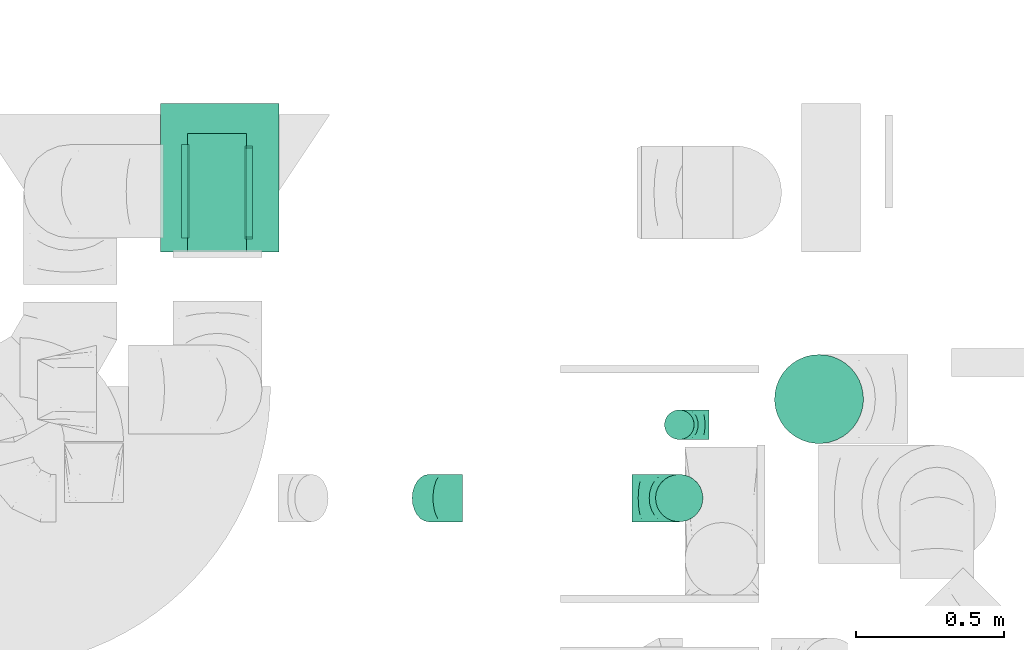
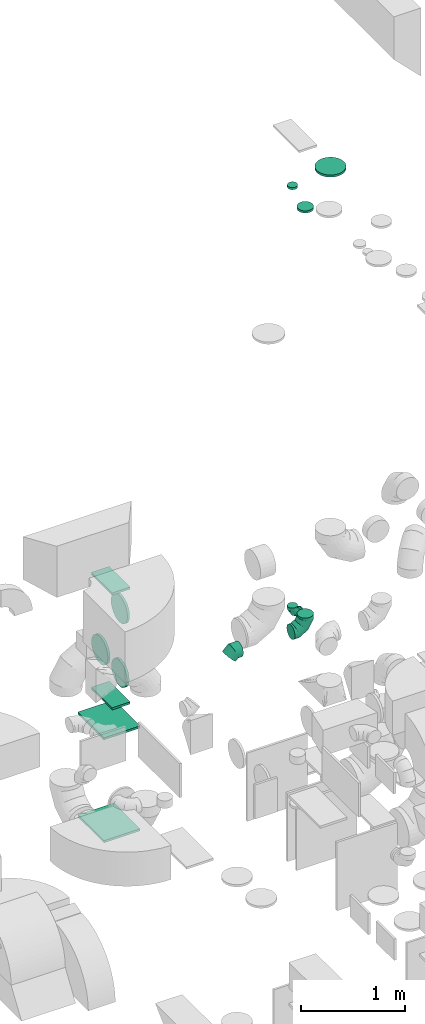
# One storey, part 33 of 59: 13 flow fittings.
"""IFC2X3 building model written with IfcOpenShell, lengths in millimetres."""

from ifc_helpers import new_model, entity, si_unit, converted_unit, derived_unit, direction, frame, origin, origin_2d_with_axis, place, context, subcontext, project, spatial, rectangle, circle, extrude, faceted_brep, source, transform, mapped, material, type_object, type_shapes, element, save


model = new_model("IFC2X3")

# Units and contexts
model_context = context("Model", 3, precision=0.01, world=origin(), true_north=direction((6.12303176911189e-17, 1.0)))
body_context = subcontext(model_context, "Body", "Model", "MODEL_VIEW")
ifc_project = project(units=[si_unit("LENGTHUNIT", "METRE", prefix="MILLI"), si_unit("AREAUNIT", "SQUARE_METRE"), si_unit("VOLUMEUNIT", "CUBIC_METRE"), converted_unit("PLANEANGLEUNIT", "DEGREE", entity("IfcRatioMeasure", 0.0174532925199433), si_unit("PLANEANGLEUNIT", "RADIAN"), dimensions=[0, 0, 0, 0, 0, 0, 0]), si_unit("MASSUNIT", "GRAM", prefix="KILO"), derived_unit("MASSDENSITYUNIT", [(si_unit("MASSUNIT", "GRAM", prefix="KILO"), 1), (si_unit("LENGTHUNIT", "METRE"), -3)]), derived_unit("MOMENTOFINERTIAUNIT", [(si_unit("LENGTHUNIT", "METRE"), 4)]), si_unit("TIMEUNIT", "SECOND"), si_unit("FREQUENCYUNIT", "HERTZ"), si_unit("THERMODYNAMICTEMPERATUREUNIT", "DEGREE_CELSIUS"), derived_unit("THERMALTRANSMITTANCEUNIT", [(si_unit("MASSUNIT", "GRAM", prefix="KILO"), 1), (si_unit("THERMODYNAMICTEMPERATUREUNIT", "KELVIN"), -1), (si_unit("TIMEUNIT", "SECOND"), -3)]), derived_unit("VOLUMETRICFLOWRATEUNIT", [(si_unit("LENGTHUNIT", "METRE"), 3), (si_unit("TIMEUNIT", "SECOND"), -1)]), derived_unit("MASSFLOWRATEUNIT", [(si_unit("MASSUNIT", "GRAM", prefix="KILO"), 1), (si_unit("TIMEUNIT", "SECOND"), -1)]), derived_unit("ROTATIONALFREQUENCYUNIT", [(si_unit("TIMEUNIT", "SECOND"), -1)]), si_unit("ELECTRICCURRENTUNIT", "AMPERE"), si_unit("ELECTRICVOLTAGEUNIT", "VOLT"), si_unit("POWERUNIT", "WATT"), si_unit("FORCEUNIT", "NEWTON", prefix="KILO"), si_unit("ILLUMINANCEUNIT", "LUX"), si_unit("LUMINOUSFLUXUNIT", "LUMEN"), si_unit("LUMINOUSINTENSITYUNIT", "CANDELA"), derived_unit("USERDEFINED", [(si_unit("MASSUNIT", "GRAM", prefix="KILO"), -1), (si_unit("LENGTHUNIT", "METRE"), -2), (si_unit("TIMEUNIT", "SECOND"), 3), (si_unit("LUMINOUSFLUXUNIT", "LUMEN"), 1)]), derived_unit("LINEARVELOCITYUNIT", [(si_unit("LENGTHUNIT", "METRE"), 1), (si_unit("TIMEUNIT", "SECOND"), -1)]), si_unit("PRESSUREUNIT", "PASCAL"), derived_unit("USERDEFINED", [(si_unit("LENGTHUNIT", "METRE"), -2), (si_unit("MASSUNIT", "GRAM", prefix="KILO"), 1), (si_unit("TIMEUNIT", "SECOND"), -2)]), derived_unit("LINEARFORCEUNIT", [(si_unit("MASSUNIT", "GRAM", prefix="KILO"), 1), (si_unit("LENGTHUNIT", "METRE"), 1), (si_unit("TIMEUNIT", "SECOND"), -2), (si_unit("LENGTHUNIT", "METRE"), -1)]), derived_unit("PLANARFORCEUNIT", [(si_unit("MASSUNIT", "GRAM", prefix="KILO"), 1), (si_unit("LENGTHUNIT", "METRE"), 1), (si_unit("TIMEUNIT", "SECOND"), -2), (si_unit("LENGTHUNIT", "METRE"), -2)])], contexts=[model_context])

# Site, building, storey
site_placement = place(None, origin())
site = spatial("IfcSite", under=ifc_project, at=site_placement, CompositionType="ELEMENT")
building_placement = place(site_placement, origin())
building = spatial("IfcBuilding", under=site, at=building_placement, CompositionType="ELEMENT")
storey_placement = place(building_placement, frame((0.0, 0.0, 28200.0)))
storey = spatial("IfcBuildingStorey", under=building, at=storey_placement, CompositionType="ELEMENT", Elevation=28200.0)

# Flow fittings
ifc_material = material()
duct_fitting_type_1 = type_object("IfcDuctFittingType", PredefinedType="NOTDEFINED", material=ifc_material)
shared_shape_1 = source(origin(), body_context, "Body", "SweptSolid", [
    extrude(circle(Radius=79.9999999999994, at=origin_2d_with_axis()), frame((0.0, 0.0, 0.0), z_axis=(1.0, 0.0, 0.0), x_axis=(0.0, 1.0, 0.0)), (0.0, 0.0, 1.0), 25.0000000000018),
])
type_shapes(duct_fitting_type_1, [shared_shape_1])
flow_fitting_1_placement = place(storey_placement, frame((55450.71, 11858.0, 7500.0), z_axis=(-1.0, 0.0, 0.0), x_axis=(0.0, 0.0, 1.0)))
element("IfcFlowFitting", 1, at=flow_fitting_1_placement, inside=storey, type_object=duct_fitting_type_1, material=ifc_material, context=body_context, shape_type="MappedRepresentation", body=[
    mapped(shared_shape_1, transform((0.0, 0.0, 0.0), scale=1.0)),
])
duct_fitting_type_2 = type_object("IfcDuctFittingType", PredefinedType="NOTDEFINED", material=ifc_material)
shared_shape_2 = source(origin(), body_context, "Body", "SweptSolid", [
    extrude(circle(Radius=49.9999999999997, at=origin_2d_with_axis()), frame((0.0, 0.0, 0.0), z_axis=(1.0, 0.0, 0.0), x_axis=(0.0, 1.0, 0.0)), (0.0, 0.0, 1.0), 25.0000000000018),
])
type_shapes(duct_fitting_type_2, [shared_shape_2])
flow_fitting_2_placement = place(storey_placement, frame((55451.0, 12105.64, 7601.3), z_axis=(-1.0, 0.0, 0.0), x_axis=(0.0, 0.0, 1.0)))
element("IfcFlowFitting", 2, at=flow_fitting_2_placement, inside=storey, type_object=duct_fitting_type_2, material=ifc_material, context=body_context, shape_type="MappedRepresentation", body=[
    mapped(shared_shape_2, transform((0.0, 0.0, 0.0), scale=1.0)),
])
duct_fitting_type_3 = type_object("IfcDuctFittingType", PredefinedType="NOTDEFINED", material=ifc_material)
shared_shape_3 = source(origin(), body_context, "Body", "SweptSolid", [
    extrude(rectangle(XDim=24.9999999999999, YDim=500.0, at=origin_2d_with_axis()), frame((12.5, 0.0, -200.0)), (0.0, 0.0, 1.0), 400.0),
])
type_shapes(duct_fitting_type_3, [shared_shape_3])
for number, where, z_axis, x_axis in (
    (3, (53900.03, 12939.46, 200.23), (-1.0, 0.0, 0.0), (0.0, 0.0, -1.0)),
    (4, (53900.03, 12939.46, 1380.23), (-1.0, 0.0, 0.0), (0.0, 0.0, 1.0)),
):
    element("IfcFlowFitting", number, at=place(storey_placement, frame(where, z_axis=z_axis, x_axis=x_axis)), inside=storey, type_object=duct_fitting_type_3, material=ifc_material, context=body_context, shape_type="MappedRepresentation", body=[
        mapped(shared_shape_3, transform((0.0, 0.0, 0.0), scale=1.0)),
    ])
duct_fitting_type_4 = type_object("IfcDuctFittingType", PredefinedType="NOTDEFINED", material=ifc_material)
shared_shape_4 = source(origin(), body_context, "Body", "SweptSolid", [
    extrude(rectangle(XDim=24.9999999999999, YDim=400.0, at=origin_2d_with_axis()), frame((12.5, 0.0, -100.0)), (0.0, 0.0, 1.0), 200.0),
])
type_shapes(duct_fitting_type_4, [shared_shape_4])
for number, where, z_axis, x_axis in (
    (5, (53890.28, 12889.46, 1725.0), (-1.0, 0.0, 0.0), (0.0, 0.0, -1.0)),
    (6, (53890.28, 12889.46, 3045.0), (-1.0, 0.0, 0.0), (0.0, 0.0, 1.0)),
):
    element("IfcFlowFitting", number, at=place(storey_placement, frame(where, z_axis=z_axis, x_axis=x_axis)), inside=storey, type_object=duct_fitting_type_4, material=ifc_material, context=body_context, shape_type="MappedRepresentation", body=[
        mapped(shared_shape_4, transform((0.0, 0.0, 0.0), scale=1.0)),
    ])
duct_fitting_type_5 = type_object("IfcDuctFittingType", PredefinedType="NOTDEFINED", material=ifc_material)
shared_shape_5 = source(origin(), body_context, "Body", "SweptSolid", [
    extrude(circle(Radius=149.999999999999, at=origin_2d_with_axis()), frame((0.0, 0.0, 0.0), z_axis=(1.0, 0.0, 0.0), x_axis=(0.0, 1.0, 0.0)), (0.0, 0.0, 1.0), 25.0000000000018),
])
type_shapes(duct_fitting_type_5, [shared_shape_5])
flow_fitting_3_placement = place(storey_placement, frame((55922.5, 12192.32, 7601.3), z_axis=(-1.0, 0.0, 0.0), x_axis=(0.0, 0.0, 1.0)))
element("IfcFlowFitting", 7, at=flow_fitting_3_placement, inside=storey, type_object=duct_fitting_type_5, material=ifc_material, context=body_context, shape_type="MappedRepresentation", body=[
    mapped(shared_shape_5, transform((0.0, 0.0, 0.0), scale=1.0)),
])
duct_fitting_type_6 = type_object("IfcDuctFittingType", PredefinedType="NOTDEFINED", material=ifc_material)
shared_shape_6 = source(origin(), body_context, "Body", "Brep", [
    faceted_brep([(-160.0, 0.0, -80.0), (-160.0, -20.71, -77.27), (-160.0, -40.0, -69.28), (-160.0, -56.57, -56.57), (-160.0, -69.28, -40.0), (-160.0, -77.27, -20.71), (-160.0, -80.0, 0.0), (-160.0, -77.27, 20.71), (-160.0, -69.28, 40.0), (-160.0, -56.57, 56.57), (-160.0, -40.0, 69.28), (-160.0, -20.71, 77.27), (-160.0, 0.0, 80.0), (-160.0, 20.71, 77.27), (-160.0, 40.0, 69.28), (-160.0, 56.57, 56.57), (-160.0, 69.28, 40.0), (-160.0, 77.27, 20.71), (-160.0, 80.0, 0.0), (-160.0, 77.27, -20.71), (-160.0, 69.28, -40.0), (-160.0, 56.57, -56.57), (-160.0, 40.0, -69.28), (-160.0, 20.71, -77.27), (-122.68, 20.71, 77.27), (-127.85, 40.0, 69.28), (-117.13, 0.0, 80.0), (-132.29, 56.57, 56.57), (-137.83, 77.27, 20.71), (-138.56, 80.0, 0.0), (-135.69, 69.28, 40.0), (-135.69, 69.28, -40.0), (-132.29, 56.57, -56.57), (-137.83, 77.27, -20.71), (-122.68, 20.71, -77.27), (-117.13, 0.0, -80.0), (-127.85, 40.0, -69.28), (-111.58, -20.71, -77.27), (-106.41, -40.0, -69.28), (-101.97, -56.57, -56.57), (-98.56, -69.28, -40.0), (-96.42, -77.27, -20.71), (-95.69, -80.0, 0.0), (-96.42, -77.27, 20.71), (-98.56, -69.28, 40.0), (-101.97, -56.57, 56.57), (-106.41, -40.0, 69.28), (-111.58, -20.71, 77.27), (-58.03, 58.03, 77.27), (-72.15, 72.15, 69.28), (-42.87, 42.87, 80.0), (-84.28, 84.28, 56.57), (-93.59, 93.59, 40.0), (-99.44, 99.44, 20.71), (-101.44, 101.44, 0.0), (-99.44, 99.44, -20.71), (-93.59, 93.59, -40.0), (-84.28, 84.28, -56.57), (-58.03, 58.03, -77.27), (-42.87, 42.87, -80.0), (-72.15, 72.15, -69.28), (-27.71, 27.71, -77.27), (-13.59, 13.59, -69.28), (-1.46, 1.46, -56.57), (7.85, -7.85, -40.0), (13.7, -13.7, -20.71), (15.69, -15.69, 0.0), (13.7, -13.7, 20.71), (7.85, -7.85, 40.0), (-1.46, 1.46, 56.57), (-13.59, 13.59, 69.28), (-27.71, 27.71, 77.27), (-20.71, 122.68, 77.27), (-40.0, 127.85, 69.28), (0.0, 117.13, 80.0), (-56.57, 132.29, 56.57), (-69.28, 135.69, 40.0), (-77.27, 137.83, 20.71), (-80.0, 138.56, 0.0), (-77.27, 137.83, -20.71), (-69.28, 135.69, -40.0), (-56.57, 132.29, -56.57), (-20.71, 122.68, -77.27), (0.0, 117.13, -80.0), (-40.0, 127.85, -69.28), (20.71, 111.58, -77.27), (40.0, 106.41, -69.28), (56.57, 101.97, -56.57), (69.28, 98.56, -40.0), (77.27, 96.42, -20.71), (80.0, 95.69, 0.0), (77.27, 96.42, 20.71), (69.28, 98.56, 40.0), (56.57, 101.97, 56.57), (40.0, 106.41, 69.28), (20.71, 111.58, 77.27), (-20.71, 160.0, -77.27), (-40.0, 160.0, -69.28), (-56.57, 160.0, -56.57), (-69.28, 160.0, -40.0), (-77.27, 160.0, -20.71), (-80.0, 160.0, 0.0), (-77.27, 160.0, 20.71), (-69.28, 160.0, 40.0), (-56.57, 160.0, 56.57), (-40.0, 160.0, 69.28), (-20.71, 160.0, 77.27), (0.0, 160.0, 80.0), (20.71, 160.0, 77.27), (40.0, 160.0, 69.28), (56.57, 160.0, 56.57), (69.28, 160.0, 40.0), (77.27, 160.0, 20.71), (80.0, 160.0, 0.0), (77.27, 160.0, -20.71), (69.28, 160.0, -40.0), (56.57, 160.0, -56.57), (40.0, 160.0, -69.28), (20.71, 160.0, -77.27), (0.0, 160.0, -80.0)], [[[0, 1, 2, 3, 4, 5, 6, 7, 8, 9, 10, 11, 12, 13, 14, 15, 16, 17, 18, 19, 20, 21, 22, 23]], [[24, 25, 14, 13]], [[26, 24, 13, 12]], [[14, 25, 27, 15]], [[28, 29, 18, 17]], [[30, 28, 17, 16]], [[15, 27, 30, 16]], [[20, 31, 32, 21]], [[33, 31, 20, 19]], [[18, 29, 33, 19]], [[34, 35, 0, 23]], [[36, 34, 23, 22]], [[32, 36, 22, 21]], [[1, 0, 35, 37]], [[2, 1, 37, 38]], [[3, 2, 38, 39]], [[5, 4, 40, 41]], [[6, 5, 41, 42]], [[39, 40, 4, 3]], [[6, 42, 43, 7]], [[7, 43, 44, 8]], [[8, 44, 45, 9]], [[9, 45, 46, 10]], [[10, 46, 47, 11]], [[26, 12, 11, 47]], [[48, 49, 25, 24]], [[50, 48, 24, 26]], [[27, 25, 49, 51]], [[52, 53, 28, 30]], [[51, 52, 30, 27]], [[29, 28, 53, 54]], [[55, 56, 31, 33]], [[54, 55, 33, 29]], [[32, 31, 56, 57]], [[58, 59, 35, 34]], [[60, 58, 34, 36]], [[57, 60, 36, 32]], [[37, 35, 59, 61]], [[38, 37, 61, 62]], [[39, 38, 62, 63]], [[41, 40, 64, 65]], [[42, 41, 65, 66]], [[63, 64, 40, 39]], [[43, 42, 66, 67]], [[44, 43, 67, 68]], [[68, 69, 45, 44]], [[46, 45, 69, 70]], [[47, 46, 70, 71]], [[26, 47, 71, 50]], [[72, 73, 49, 48]], [[74, 72, 48, 50]], [[51, 49, 73, 75]], [[76, 77, 53, 52]], [[75, 76, 52, 51]], [[54, 53, 77, 78]], [[79, 80, 56, 55]], [[78, 79, 55, 54]], [[57, 56, 80, 81]], [[82, 83, 59, 58]], [[84, 82, 58, 60]], [[81, 84, 60, 57]], [[61, 59, 83, 85]], [[62, 61, 85, 86]], [[63, 62, 86, 87]], [[65, 64, 88, 89]], [[66, 65, 89, 90]], [[87, 88, 64, 63]], [[67, 66, 90, 91]], [[68, 67, 91, 92]], [[92, 93, 69, 68]], [[70, 69, 93, 94]], [[71, 70, 94, 95]], [[50, 71, 95, 74]], [[96, 97, 98, 99, 100, 101, 102, 103, 104, 105, 106, 107, 108, 109, 110, 111, 112, 113, 114, 115, 116, 117, 118, 119]], [[72, 74, 107, 106]], [[73, 72, 106, 105]], [[75, 73, 105, 104]], [[77, 76, 103, 102]], [[78, 77, 102, 101]], [[75, 104, 103, 76]], [[78, 101, 100, 79]], [[79, 100, 99, 80]], [[80, 99, 98, 81]], [[84, 97, 96, 82]], [[82, 96, 119, 83]], [[84, 81, 98, 97]], [[118, 117, 86, 85]], [[119, 118, 85, 83]], [[116, 87, 86, 117]], [[88, 115, 114, 89]], [[89, 114, 113, 90]], [[115, 88, 87, 116]], [[112, 111, 92, 91]], [[113, 112, 91, 90]], [[111, 110, 93, 92]], [[95, 94, 109, 108]], [[74, 95, 108, 107]], [[110, 109, 94, 93]]]),
])
type_shapes(duct_fitting_type_6, [shared_shape_6])
flow_fitting_4_placement = place(storey_placement, frame((55450.71, 11858.0, 2595.0), z_axis=(0.0, 1.0, 0.0), x_axis=(0.0, 0.0, -1.0)))
element("IfcFlowFitting", 8, at=flow_fitting_4_placement, inside=storey, type_object=duct_fitting_type_6, material=ifc_material, context=body_context, shape_type="MappedRepresentation", body=[
    mapped(shared_shape_6, transform((0.0, 0.0, 0.0), scale=1.0)),
])
duct_fitting_type_7 = type_object("IfcDuctFittingType", PredefinedType="NOTDEFINED", material=ifc_material)
shared_shape_7 = source(origin(), body_context, "Body", "Brep", [
    faceted_brep([(-100.0, 0.0, -50.0), (-100.0, -12.94, -48.3), (-100.0, -25.0, -43.3), (-100.0, -35.36, -35.36), (-100.0, -43.3, -25.0), (-100.0, -48.3, -12.94), (-100.0, -50.0, 0.0), (-100.0, -48.3, 12.94), (-100.0, -43.3, 25.0), (-100.0, -35.36, 35.36), (-100.0, -25.0, 43.3), (-100.0, -12.94, 48.3), (-100.0, 0.0, 50.0), (-100.0, 12.94, 48.3), (-100.0, 25.0, 43.3), (-100.0, 35.36, 35.36), (-100.0, 43.3, 25.0), (-100.0, 48.3, 12.94), (-100.0, 50.0, 0.0), (-100.0, 48.3, -12.94), (-100.0, 43.3, -25.0), (-100.0, 35.36, -35.36), (-100.0, 25.0, -43.3), (-100.0, 12.94, -48.3), (-76.67, 12.94, 48.3), (-79.9, 25.0, 43.3), (-73.21, 0.0, 50.0), (-82.68, 35.36, 35.36), (-86.15, 48.3, 12.94), (-86.6, 50.0, 0.0), (-84.81, 43.3, 25.0), (-84.81, 43.3, -25.0), (-82.68, 35.36, -35.36), (-86.15, 48.3, -12.94), (-76.67, 12.94, -48.3), (-73.21, 0.0, -50.0), (-79.9, 25.0, -43.3), (-69.74, -12.94, -48.3), (-66.51, -25.0, -43.3), (-63.73, -35.36, -35.36), (-61.6, -43.3, -25.0), (-60.26, -48.3, -12.94), (-59.81, -50.0, 0.0), (-60.26, -48.3, 12.94), (-61.6, -43.3, 25.0), (-63.73, -35.36, 35.36), (-66.51, -25.0, 43.3), (-69.74, -12.94, 48.3), (-36.27, 36.27, 48.3), (-45.1, 45.1, 43.3), (-26.79, 26.79, 50.0), (-52.68, 52.68, 35.36), (-58.49, 58.49, 25.0), (-62.15, 62.15, 12.94), (-63.4, 63.4, 0.0), (-62.15, 62.15, -12.94), (-58.49, 58.49, -25.0), (-52.68, 52.68, -35.36), (-36.27, 36.27, -48.3), (-26.79, 26.79, -50.0), (-45.1, 45.1, -43.3), (-17.32, 17.32, -48.3), (-8.49, 8.49, -43.3), (-0.91, 0.91, -35.36), (4.9, -4.9, -25.0), (8.56, -8.56, -12.94), (9.81, -9.81, 0.0), (8.56, -8.56, 12.94), (4.9, -4.9, 25.0), (-0.91, 0.91, 35.36), (-8.49, 8.49, 43.3), (-17.32, 17.32, 48.3), (-12.94, 76.67, 48.3), (-25.0, 79.9, 43.3), (0.0, 73.21, 50.0), (-35.36, 82.68, 35.36), (-43.3, 84.81, 25.0), (-48.3, 86.15, 12.94), (-50.0, 86.6, 0.0), (-48.3, 86.15, -12.94), (-43.3, 84.81, -25.0), (-35.36, 82.68, -35.36), (-12.94, 76.67, -48.3), (0.0, 73.21, -50.0), (-25.0, 79.9, -43.3), (12.94, 69.74, -48.3), (25.0, 66.51, -43.3), (35.36, 63.73, -35.36), (43.3, 61.6, -25.0), (48.3, 60.26, -12.94), (50.0, 59.81, 0.0), (48.3, 60.26, 12.94), (43.3, 61.6, 25.0), (35.36, 63.73, 35.36), (25.0, 66.51, 43.3), (12.94, 69.74, 48.3), (-12.94, 100.0, -48.3), (-25.0, 100.0, -43.3), (-35.36, 100.0, -35.36), (-43.3, 100.0, -25.0), (-48.3, 100.0, -12.94), (-50.0, 100.0, 0.0), (-48.3, 100.0, 12.94), (-43.3, 100.0, 25.0), (-35.36, 100.0, 35.36), (-25.0, 100.0, 43.3), (-12.94, 100.0, 48.3), (0.0, 100.0, 50.0), (12.94, 100.0, 48.3), (25.0, 100.0, 43.3), (35.36, 100.0, 35.36), (43.3, 100.0, 25.0), (48.3, 100.0, 12.94), (50.0, 100.0, 0.0), (48.3, 100.0, -12.94), (43.3, 100.0, -25.0), (35.36, 100.0, -35.36), (25.0, 100.0, -43.3), (12.94, 100.0, -48.3), (0.0, 100.0, -50.0)], [[[0, 1, 2, 3, 4, 5, 6, 7, 8, 9, 10, 11, 12, 13, 14, 15, 16, 17, 18, 19, 20, 21, 22, 23]], [[24, 25, 14, 13]], [[26, 24, 13, 12]], [[14, 25, 27, 15]], [[28, 29, 18, 17]], [[30, 28, 17, 16]], [[15, 27, 30, 16]], [[20, 31, 32, 21]], [[33, 31, 20, 19]], [[18, 29, 33, 19]], [[34, 35, 0, 23]], [[36, 34, 23, 22]], [[32, 36, 22, 21]], [[2, 1, 37, 38]], [[3, 2, 38, 39]], [[0, 35, 37, 1]], [[5, 4, 40, 41]], [[6, 5, 41, 42]], [[3, 39, 40, 4]], [[6, 42, 43, 7]], [[7, 43, 44, 8]], [[8, 44, 45, 9]], [[10, 46, 47, 11]], [[11, 47, 26, 12]], [[10, 9, 45, 46]], [[48, 49, 25, 24]], [[50, 48, 24, 26]], [[27, 25, 49, 51]], [[52, 53, 28, 30]], [[51, 52, 30, 27]], [[29, 28, 53, 54]], [[55, 56, 31, 33]], [[54, 55, 33, 29]], [[57, 32, 31, 56]], [[58, 59, 35, 34]], [[60, 58, 34, 36]], [[57, 60, 36, 32]], [[37, 35, 59, 61]], [[38, 37, 61, 62]], [[39, 38, 62, 63]], [[41, 40, 64, 65]], [[42, 41, 65, 66]], [[63, 64, 40, 39]], [[43, 42, 66, 67]], [[44, 43, 67, 68]], [[68, 69, 45, 44]], [[46, 45, 69, 70]], [[47, 46, 70, 71]], [[26, 47, 71, 50]], [[72, 73, 49, 48]], [[74, 72, 48, 50]], [[51, 49, 73, 75]], [[76, 77, 53, 52]], [[75, 76, 52, 51]], [[54, 53, 77, 78]], [[79, 80, 56, 55]], [[78, 79, 55, 54]], [[81, 57, 56, 80]], [[82, 83, 59, 58]], [[84, 82, 58, 60]], [[81, 84, 60, 57]], [[61, 59, 83, 85]], [[62, 61, 85, 86]], [[63, 62, 86, 87]], [[65, 64, 88, 89]], [[66, 65, 89, 90]], [[87, 88, 64, 63]], [[67, 66, 90, 91]], [[68, 67, 91, 92]], [[92, 93, 69, 68]], [[70, 69, 93, 94]], [[71, 70, 94, 95]], [[50, 71, 95, 74]], [[96, 97, 98, 99, 100, 101, 102, 103, 104, 105, 106, 107, 108, 109, 110, 111, 112, 113, 114, 115, 116, 117, 118, 119]], [[72, 74, 107, 106]], [[73, 72, 106, 105]], [[75, 73, 105, 104]], [[77, 76, 103, 102]], [[78, 77, 102, 101]], [[75, 104, 103, 76]], [[78, 101, 100, 79]], [[79, 100, 99, 80]], [[80, 99, 98, 81]], [[96, 119, 83, 82]], [[97, 96, 82, 84]], [[84, 81, 98, 97]], [[83, 119, 118, 85]], [[85, 118, 117, 86]], [[86, 117, 116, 87]], [[88, 115, 114, 89]], [[89, 114, 113, 90]], [[87, 116, 115, 88]], [[91, 90, 113, 112]], [[92, 91, 112, 111]], [[93, 92, 111, 110]], [[95, 94, 109, 108]], [[74, 95, 108, 107]], [[110, 109, 94, 93]]]),
])
type_shapes(duct_fitting_type_7, [shared_shape_7])
flow_fitting_5_placement = place(storey_placement, frame((55451.0, 12105.64, 2600.0), z_axis=(0.0, 1.0, 0.0), x_axis=(-1.0, 0.0, 0.0)))
element("IfcFlowFitting", 9, at=flow_fitting_5_placement, inside=storey, type_object=duct_fitting_type_7, material=ifc_material, context=body_context, shape_type="MappedRepresentation", body=[
    mapped(shared_shape_7, transform((0.0, 0.0, 0.0), scale=1.0)),
])
duct_fitting_type_8 = type_object("IfcDuctFittingType", PredefinedType="NOTDEFINED", material=ifc_material)
shared_shape_8 = source(origin(), body_context, "Body", "Brep", [
    faceted_brep([(-66.27, 0.0, -80.0), (-66.27, -20.71, -77.27), (-66.27, -40.0, -69.28), (-66.27, -56.57, -56.57), (-66.27, -69.28, -40.0), (-66.27, -77.27, -20.71), (-66.27, -80.0, 0.0), (-66.27, -77.27, 20.71), (-66.27, -69.28, 40.0), (-66.27, -56.57, 56.57), (-66.27, -40.0, 69.28), (-66.27, -20.71, 77.27), (-66.27, 0.0, 80.0), (-66.27, 20.71, 77.27), (-66.27, 40.0, 69.28), (-66.27, 56.57, 56.57), (-66.27, 69.28, 40.0), (-66.27, 77.27, 20.71), (-66.27, 80.0, 0.0), (-66.27, 77.27, -20.71), (-66.27, 69.28, -40.0), (-66.27, 56.57, -56.57), (-66.27, 40.0, -69.28), (-66.27, 20.71, -77.27), (-8.58, 20.71, 77.27), (-16.57, 40.0, 69.28), (0.0, 0.0, 80.0), (-23.43, 56.57, 56.57), (-28.7, 69.28, 40.0), (-32.01, 77.27, 20.71), (-33.14, 80.0, 0.0), (-32.01, 77.27, -20.71), (-28.7, 69.28, -40.0), (-23.43, 56.57, -56.57), (-8.58, 20.71, -77.27), (0.0, 0.0, -80.0), (-16.57, 40.0, -69.28), (8.58, -20.71, -77.27), (16.57, -40.0, -69.28), (23.43, -56.57, -56.57), (28.7, -69.28, -40.0), (32.01, -77.27, -20.71), (33.14, -80.0, 0.0), (32.01, -77.27, 20.71), (28.7, -69.28, 40.0), (23.43, -56.57, 56.57), (16.57, -40.0, 69.28), (8.58, -20.71, 77.27), (46.86, 46.86, 80.0), (32.22, 61.5, 77.27), (18.58, 75.15, 69.28), (6.86, 86.86, 56.57), (-2.13, 95.85, 40.0), (-7.78, 101.5, 20.71), (-9.71, 103.43, 0.0), (-7.78, 101.5, -20.71), (-2.13, 95.85, -40.0), (6.86, 86.86, -56.57), (18.58, 75.15, -69.28), (32.22, 61.5, -77.27), (46.86, 46.86, -80.0), (61.5, 32.22, -77.27), (75.15, 18.58, -69.28), (86.86, 6.86, -56.57), (95.85, -2.13, -40.0), (101.5, -7.78, -20.71), (103.43, -9.71, 0.0), (101.5, -7.78, 20.71), (95.85, -2.13, 40.0), (86.86, 6.86, 56.57), (75.15, 18.58, 69.28), (61.5, 32.22, 77.27)], [[[0, 1, 2, 3, 4, 5, 6, 7, 8, 9, 10, 11, 12, 13, 14, 15, 16, 17, 18, 19, 20, 21, 22, 23]], [[24, 25, 14, 13]], [[26, 24, 13, 12]], [[14, 25, 27, 15]], [[28, 29, 17, 16]], [[28, 16, 15, 27]], [[30, 18, 17, 29]], [[31, 32, 20, 19]], [[30, 31, 19, 18]], [[32, 33, 21, 20]], [[34, 35, 0, 23]], [[36, 34, 23, 22]], [[33, 36, 22, 21]], [[1, 0, 35, 37]], [[2, 1, 37, 38]], [[38, 39, 3, 2]], [[5, 4, 40, 41]], [[6, 5, 41, 42]], [[39, 40, 4, 3]], [[6, 42, 43, 7]], [[7, 43, 44, 8]], [[8, 44, 45, 9]], [[9, 45, 46, 10]], [[10, 46, 47, 11]], [[26, 12, 11, 47]], [[24, 26, 48, 49]], [[25, 24, 49, 50]], [[27, 25, 50, 51]], [[29, 28, 52, 53]], [[30, 29, 53, 54]], [[51, 52, 28, 27]], [[30, 54, 55, 31]], [[31, 55, 56, 32]], [[57, 33, 32, 56]], [[36, 58, 59, 34]], [[34, 59, 60, 35]], [[58, 36, 33, 57]], [[35, 60, 61, 37]], [[37, 61, 62, 38]], [[63, 39, 38, 62]], [[40, 64, 65, 41]], [[41, 65, 66, 42]], [[64, 40, 39, 63]], [[43, 42, 66, 67]], [[44, 43, 67, 68]], [[68, 69, 45, 44]], [[47, 46, 70, 71]], [[26, 47, 71, 48]], [[69, 70, 46, 45]], [[59, 58, 57, 56, 55, 54, 53, 52, 51, 50, 49, 48, 71, 70, 69, 68, 67, 66, 65, 64, 63, 62, 61, 60]]]),
])
type_shapes(duct_fitting_type_8, [shared_shape_8])
flow_fitting_6_placement = place(storey_placement, frame((54652.65, 11858.0, 2595.0), z_axis=(0.0, -1.0, 0.0), x_axis=(-1.0, 0.0, 0.0)))
element("IfcFlowFitting", 10, at=flow_fitting_6_placement, inside=storey, type_object=duct_fitting_type_8, material=ifc_material, context=body_context, shape_type="MappedRepresentation", body=[
    mapped(shared_shape_8, transform((0.0, 0.0, 0.0), scale=1.0)),
])
duct_fitting_type_9 = type_object("IfcDuctFittingType", PredefinedType="NOTDEFINED", material=ifc_material)
shared_shape_9 = source(origin(), body_context, "Body", "Brep", [
    faceted_brep([(20.0, 40.76, -152.13), (20.0, 78.75, -136.4), (20.0, 111.37, -111.37), (20.0, 136.4, -78.75), (20.0, 152.13, -40.76), (20.0, 157.5, 0.0), (20.0, 152.13, 40.76), (20.0, 136.4, 78.75), (20.0, 111.37, 111.37), (20.0, 78.75, 136.4), (20.0, 40.76, 152.13), (20.0, 0.0, 157.5), (20.0, -40.76, 152.13), (20.0, -78.75, 136.4), (20.0, -111.37, 111.37), (20.0, -136.4, 78.75), (20.0, -152.13, 40.76), (20.0, -157.5, 0.0), (20.0, -152.13, -40.76), (20.0, -136.4, -78.75), (20.0, -111.37, -111.37), (20.0, -78.75, -136.4), (20.0, -40.76, -152.13), (20.0, 0.0, -157.5), (0.0, 0.0, 157.5), (0.0, 40.76, 152.13), (-6.1, 40.76, 152.13), (-6.1, 0.0, 157.5), (0.0, 78.75, 136.4), (-6.1, 78.75, 136.4), (0.0, 111.37, 111.37), (-6.1, 111.37, 111.37), (0.0, 136.4, 78.75), (0.0, 152.13, 40.76), (-6.1, 152.13, 40.76), (-6.1, 136.4, 78.75), (0.0, 157.5, 0.0), (-6.1, 157.5, 0.0), (0.0, 152.13, -40.76), (-6.1, 152.13, -40.76), (0.0, 136.4, -78.75), (-6.1, 136.4, -78.75), (0.0, 111.37, -111.37), (-6.1, 111.37, -111.37), (0.0, 0.0, -157.5), (-6.1, 0.0, -157.5), (-6.1, 40.76, -152.13), (0.0, 40.76, -152.13), (-6.1, 78.75, -136.4), (0.0, 78.75, -136.4), (0.0, -40.76, -152.13), (-6.1, -40.76, -152.13), (0.0, -78.75, -136.4), (-6.1, -78.75, -136.4), (0.0, -111.37, -111.37), (-6.1, -111.37, -111.37), (0.0, -136.4, -78.75), (0.0, -152.13, -40.76), (-6.1, -152.13, -40.76), (-6.1, -136.4, -78.75), (0.0, -157.5, 0.0), (-6.1, -157.5, 0.0), (0.0, -152.13, 40.76), (-6.1, -152.13, 40.76), (0.0, -136.4, 78.75), (-6.1, -136.4, 78.75), (0.0, -111.37, 111.37), (-6.1, -111.37, 111.37), (0.0, -78.75, 136.4), (0.0, -40.76, 152.13), (-6.1, -40.76, 152.13), (-6.1, -78.75, 136.4)], [[[0, 1, 2, 3, 4, 5, 6, 7, 8, 9, 10, 11, 12, 13, 14, 15, 16, 17, 18, 19, 20, 21, 22, 23]], [[24, 11, 10, 25, 26, 27]], [[25, 10, 9, 28, 29, 26]], [[28, 9, 8, 30, 31, 29]], [[32, 7, 6, 33, 34, 35]], [[33, 6, 5, 36, 37, 34]], [[30, 8, 7, 32, 35, 31]], [[36, 5, 4, 38, 39, 37]], [[38, 4, 3, 40, 41, 39]], [[40, 3, 2, 42, 43, 41]], [[0, 23, 44, 45, 46, 47]], [[1, 0, 47, 46, 48, 49]], [[49, 48, 43, 42, 2, 1]], [[44, 23, 22, 50, 51, 45]], [[50, 22, 21, 52, 53, 51]], [[52, 21, 20, 54, 55, 53]], [[56, 19, 18, 57, 58, 59]], [[57, 18, 17, 60, 61, 58]], [[54, 20, 19, 56, 59, 55]], [[60, 17, 16, 62, 63, 61]], [[62, 16, 15, 64, 65, 63]], [[64, 15, 14, 66, 67, 65]], [[68, 13, 12, 69, 70, 71]], [[69, 12, 11, 24, 27, 70]], [[66, 14, 13, 68, 71, 67]], [[45, 51, 53, 55, 59, 58, 61, 63, 65, 67, 71, 70, 27, 26, 29, 31, 35, 34, 37, 39, 41, 43, 48, 46]]]),
])
type_shapes(duct_fitting_type_9, [shared_shape_9])
for number, where, z_axis, x_axis in (
    (11, (53790.28, 12893.51, 2289.55), (0.0, -1.0, 0.0), (-1.0, 0.0, 0.0)),
    (12, (53990.28, 12889.46, 2700.0), (0.0, -1.0, 0.0), (1.0, 0.0, 0.0)),
):
    element("IfcFlowFitting", number, at=place(storey_placement, frame(where, z_axis=z_axis, x_axis=x_axis)), inside=storey, type_object=duct_fitting_type_9, material=ifc_material, context=body_context, shape_type="MappedRepresentation", body=[
        mapped(shared_shape_9, transform((0.0, 0.0, 0.0), scale=1.0)),
    ])
duct_fitting_type_10 = type_object("IfcDuctFittingType", PredefinedType="NOTDEFINED", material=ifc_material)
shared_shape_10 = source(origin(), body_context, "Body", "Brep", [
    faceted_brep([(20.0, 0.0, -150.0), (20.0, 38.82, -144.89), (20.0, 75.0, -129.9), (20.0, 106.07, -106.07), (20.0, 129.9, -75.0), (20.0, 144.89, -38.82), (20.0, 150.0, 0.0), (20.0, 144.89, 38.82), (20.0, 129.9, 75.0), (20.0, 106.07, 106.07), (20.0, 75.0, 129.9), (20.0, 38.82, 144.89), (20.0, 0.0, 150.0), (20.0, -38.82, 144.89), (20.0, -75.0, 129.9), (20.0, -106.07, 106.07), (20.0, -129.9, 75.0), (20.0, -144.89, 38.82), (20.0, -150.0, 0.0), (20.0, -144.89, -38.82), (20.0, -129.9, -75.0), (20.0, -106.07, -106.07), (20.0, -75.0, -129.9), (20.0, -38.82, -144.89), (0.0, 0.0, 150.0), (-6.1, 0.0, 150.0), (-6.1, -38.82, 144.89), (0.0, -38.82, 144.89), (-6.1, -75.0, 129.9), (0.0, -75.0, 129.9), (0.0, -106.07, 106.07), (-6.1, -106.07, 106.07), (0.0, -129.9, 75.0), (-6.1, -129.9, 75.0), (-6.1, -144.89, 38.82), (0.0, -144.89, 38.82), (-6.1, -150.0, 0.0), (0.0, -150.0, 0.0), (-6.1, -144.89, -38.82), (0.0, -144.89, -38.82), (-6.1, -129.9, -75.0), (0.0, -129.9, -75.0), (0.0, -106.07, -106.07), (-6.1, -106.07, -106.07), (0.0, -75.0, -129.9), (-6.1, -75.0, -129.9), (-6.1, -38.82, -144.89), (0.0, -38.82, -144.89), (-6.1, 0.0, -150.0), (0.0, 0.0, -150.0), (-6.1, 38.82, -144.89), (0.0, 38.82, -144.89), (-6.1, 75.0, -129.9), (0.0, 75.0, -129.9), (0.0, 106.07, -106.07), (-6.1, 106.07, -106.07), (0.0, 129.9, -75.0), (-6.1, 129.9, -75.0), (-6.1, 144.89, -38.82), (0.0, 144.89, -38.82), (-6.1, 150.0, 0.0), (0.0, 150.0, 0.0), (-6.1, 144.89, 38.82), (0.0, 144.89, 38.82), (-6.1, 129.9, 75.0), (0.0, 129.9, 75.0), (0.0, 106.07, 106.07), (-6.1, 106.07, 106.07), (0.0, 75.0, 129.9), (-6.1, 75.0, 129.9), (-6.1, 38.82, 144.89), (0.0, 38.82, 144.89)], [[[0, 1, 2, 3, 4, 5, 6, 7, 8, 9, 10, 11, 12, 13, 14, 15, 16, 17, 18, 19, 20, 21, 22, 23]], [[13, 12, 24, 25, 26, 27]], [[14, 13, 27, 26, 28, 29]], [[30, 15, 14, 29, 28, 31]], [[17, 16, 32, 33, 34, 35]], [[18, 17, 35, 34, 36, 37]], [[32, 16, 15, 30, 31, 33]], [[19, 18, 37, 36, 38, 39]], [[20, 19, 39, 38, 40, 41]], [[42, 21, 20, 41, 40, 43]], [[23, 22, 44, 45, 46, 47]], [[0, 23, 47, 46, 48, 49]], [[44, 22, 21, 42, 43, 45]], [[1, 0, 49, 48, 50, 51]], [[2, 1, 51, 50, 52, 53]], [[54, 3, 2, 53, 52, 55]], [[5, 4, 56, 57, 58, 59]], [[6, 5, 59, 58, 60, 61]], [[56, 4, 3, 54, 55, 57]], [[7, 6, 61, 60, 62, 63]], [[8, 7, 63, 62, 64, 65]], [[66, 9, 8, 65, 64, 67]], [[11, 10, 68, 69, 70, 71]], [[12, 11, 71, 70, 25, 24]], [[68, 10, 9, 66, 67, 69]], [[46, 45, 43, 40, 38, 36, 34, 33, 31, 28, 26, 25, 70, 69, 67, 64, 62, 60, 58, 57, 55, 52, 50, 48]]]),
])
type_shapes(duct_fitting_type_10, [shared_shape_10])
flow_fitting_7_placement = place(storey_placement, frame((53990.28, 12889.46, 1945.51), z_axis=(0.0, -1.0, 0.0), x_axis=(1.0, 0.0, 0.0)))
element("IfcFlowFitting", 13, at=flow_fitting_7_placement, inside=storey, type_object=duct_fitting_type_10, material=ifc_material, context=body_context, shape_type="MappedRepresentation", body=[
    mapped(shared_shape_10, transform((0.0, 0.0, 0.0), scale=1.0)),
])

save(model, "model.ifc")
